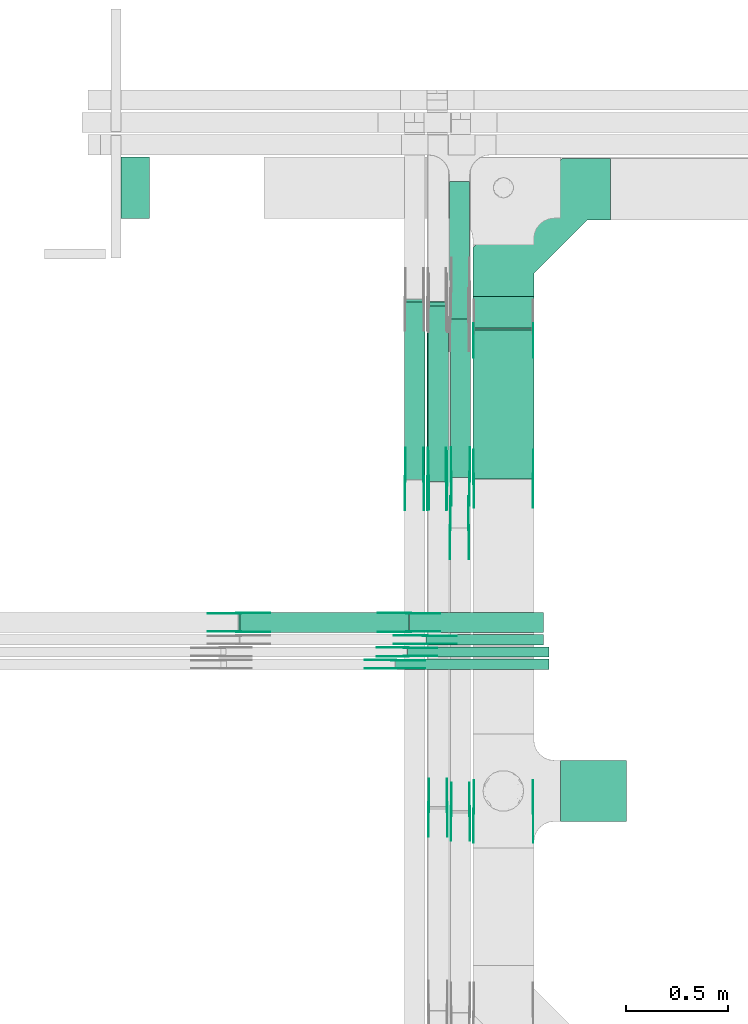
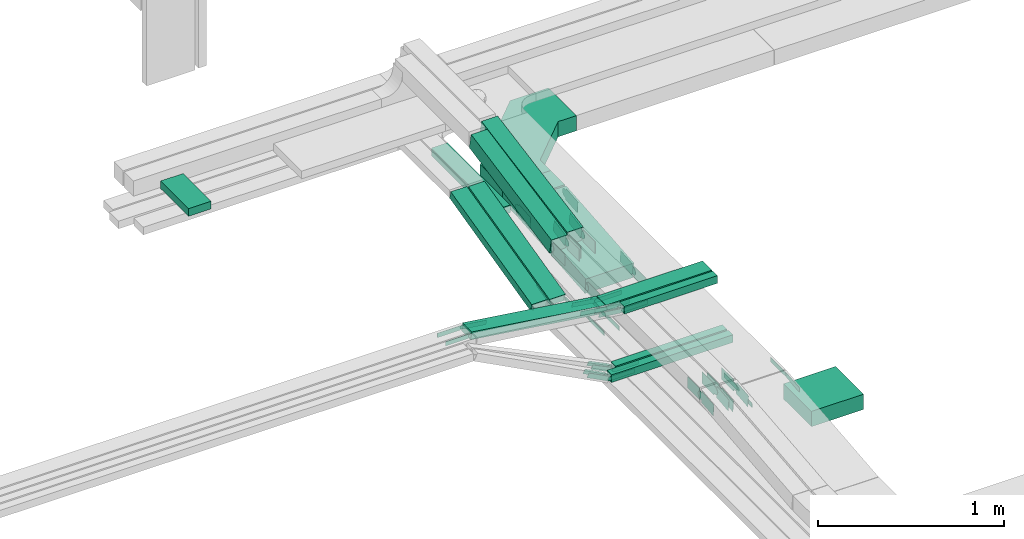
# One storey, part 8 of 33: 59 flow fittings, 14 flow segments.
"""IFC2X3 building model written with IfcOpenShell, lengths in millimetres."""

from ifc_helpers import new_model, entity, si_unit, converted_unit, derived_unit, direction, frame, frame_2d, origin, origin_2d_with_axis, place, context, subcontext, project, spatial, polyline, circle_curve, parameter, trimmed, segment, composite_curve, rectangle, outline, extrude, source, transform, mapped, material, type_object, type_shapes, element, save


model = new_model("IFC2X3")

# Units and contexts
model_context = context("Model", 3, precision=0.01, world=origin(), true_north=direction((6.12303176911189e-17, 1.0)))
body_context = subcontext(model_context, "Body", "Model", "MODEL_VIEW")
ifc_project = project(units=[si_unit("LENGTHUNIT", "METRE", prefix="MILLI"), si_unit("AREAUNIT", "SQUARE_METRE"), si_unit("VOLUMEUNIT", "CUBIC_METRE"), converted_unit("PLANEANGLEUNIT", "DEGREE", entity("IfcRatioMeasure", 0.0174532925199433), si_unit("PLANEANGLEUNIT", "RADIAN"), dimensions=[0, 0, 0, 0, 0, 0, 0]), si_unit("MASSUNIT", "GRAM", prefix="KILO"), derived_unit("MASSDENSITYUNIT", [(si_unit("MASSUNIT", "GRAM", prefix="KILO"), 1), (si_unit("LENGTHUNIT", "METRE"), -3)]), derived_unit("MOMENTOFINERTIAUNIT", [(si_unit("LENGTHUNIT", "METRE"), 4)]), si_unit("TIMEUNIT", "SECOND"), si_unit("FREQUENCYUNIT", "HERTZ"), si_unit("THERMODYNAMICTEMPERATUREUNIT", "DEGREE_CELSIUS"), derived_unit("THERMALTRANSMITTANCEUNIT", [(si_unit("MASSUNIT", "GRAM", prefix="KILO"), 1), (si_unit("THERMODYNAMICTEMPERATUREUNIT", "KELVIN"), -1), (si_unit("TIMEUNIT", "SECOND"), -3)]), derived_unit("VOLUMETRICFLOWRATEUNIT", [(si_unit("LENGTHUNIT", "METRE"), 3), (si_unit("TIMEUNIT", "SECOND"), -1)]), derived_unit("MASSFLOWRATEUNIT", [(si_unit("MASSUNIT", "GRAM", prefix="KILO"), 1), (si_unit("TIMEUNIT", "SECOND"), -1)]), derived_unit("ROTATIONALFREQUENCYUNIT", [(si_unit("TIMEUNIT", "SECOND"), -1)]), si_unit("ELECTRICCURRENTUNIT", "AMPERE"), si_unit("ELECTRICVOLTAGEUNIT", "VOLT"), si_unit("POWERUNIT", "WATT"), si_unit("FORCEUNIT", "NEWTON", prefix="KILO"), si_unit("ILLUMINANCEUNIT", "LUX"), si_unit("LUMINOUSFLUXUNIT", "LUMEN"), si_unit("LUMINOUSINTENSITYUNIT", "CANDELA"), derived_unit("USERDEFINED", [(si_unit("MASSUNIT", "GRAM", prefix="KILO"), -1), (si_unit("LENGTHUNIT", "METRE"), -2), (si_unit("TIMEUNIT", "SECOND"), 3), (si_unit("LUMINOUSFLUXUNIT", "LUMEN"), 1)]), derived_unit("LINEARVELOCITYUNIT", [(si_unit("LENGTHUNIT", "METRE"), 1), (si_unit("TIMEUNIT", "SECOND"), -1)]), si_unit("PRESSUREUNIT", "PASCAL"), derived_unit("USERDEFINED", [(si_unit("LENGTHUNIT", "METRE"), -2), (si_unit("MASSUNIT", "GRAM", prefix="KILO"), 1), (si_unit("TIMEUNIT", "SECOND"), -2)]), derived_unit("LINEARFORCEUNIT", [(si_unit("MASSUNIT", "GRAM", prefix="KILO"), 1), (si_unit("LENGTHUNIT", "METRE"), 1), (si_unit("TIMEUNIT", "SECOND"), -2), (si_unit("LENGTHUNIT", "METRE"), -1)]), derived_unit("PLANARFORCEUNIT", [(si_unit("MASSUNIT", "GRAM", prefix="KILO"), 1), (si_unit("LENGTHUNIT", "METRE"), 1), (si_unit("TIMEUNIT", "SECOND"), -2), (si_unit("LENGTHUNIT", "METRE"), -2)])], contexts=[model_context])

# Site, building, storey
site_placement = place(None, frame((0.0, -0.00077364408347762, 0.0)))
site = spatial("IfcSite", under=ifc_project, at=site_placement, CompositionType="ELEMENT")
building_placement = place(site_placement, origin())
building = spatial("IfcBuilding", under=site, at=building_placement, CompositionType="ELEMENT")
storey_placement = place(building_placement, frame((0.0, 0.0, 8100.0)))
storey = spatial("IfcBuildingStorey", under=building, at=storey_placement, CompositionType="ELEMENT", Elevation=8100.0)

# Flow segments
cable_carrier_segment_type = type_object("IfcCableCarrierSegmentType", PredefinedType="CABLETRAYSEGMENT")
flow_segment_1_placement = place(storey_placement, frame((18676.0523642072, 11226.2465616803, 2500.0)))
element("IfcFlowSegment", 1, at=flow_segment_1_placement, inside=storey, type_object=cable_carrier_segment_type, context=body_context, shape_type="SweptSolid", body=[
    extrude(rectangle(XDim=322.50000000005, YDim=300.000000000001, at=frame_2d((1.09423581307055e-12, -1.08002495835535e-12), x_axis=(1.0, 0.0))), frame((161.250000000024, 150.0, 0.0)), (0.0, 0.0, 1.0), 99.9999999999989),
])
flow_segment_2_placement = place(storey_placement, frame((18246.0523642072, 13645.8761095776, 2565.0)))
element("IfcFlowSegment", 2, at=flow_segment_2_placement, inside=storey, type_object=cable_carrier_segment_type, context=body_context, shape_type="SweptSolid", body=[
    extrude(rectangle(XDim=152.623116778442, YDim=300.000000000001, at=origin_2d_with_axis()), frame((150.0, 76.3115583892504, 0.0), z_axis=(0.0, 0.0, 1.0), x_axis=(0.0, 1.0, 0.0)), (0.0, 0.0, 1.0), 100.000000000001),
])
flow_segment_3_placement = place(storey_placement, frame((18246.0523642072, 12903.9587974972, 2500.48936950024)))
element("IfcFlowSegment", 3, at=flow_segment_3_placement, inside=storey, type_object=cable_carrier_segment_type, context=body_context, shape_type="SweptSolid", body=[
    extrude(rectangle(XDim=99.9999999999982, YDim=733.623391012319, at=frame_2d((1.05160324892495e-12, -9.59232693276135e-14), x_axis=(0.0, 1.0))), frame((0.0, 369.784999621505, 82.0106304997698), z_axis=(1.0, 0.0, 0.0), x_axis=(0.0, -0.996138692653759, -0.0877935361974901)), (0.0, 0.0, 1.0), 300.000000000001),
])
flow_segment_4_placement = place(storey_placement, frame((18131.0123642174, 13688.0907678717, 2565.34290576127)))
element("IfcFlowSegment", 4, at=flow_segment_4_placement, inside=storey, type_object=cable_carrier_segment_type, context=body_context, shape_type="SweptSolid", body=[
    extrude(rectangle(XDim=674.18746787465, YDim=99.9999999999989, at=frame_2d((-1.08002495835535e-12, -1.08357767203415e-12), x_axis=(1.0, 0.0))), frame((50.0, 337.093733937324, 0.0), z_axis=(0.0, 0.0, 1.0), x_axis=(0.0, -1.0, 0.0)), (0.0, 0.0, 1.0), 50.0000000000016),
])
flow_segment_5_placement = place(storey_placement, frame((17911.0123642174, 12903.423065774, 2501.78649472544)))
element("IfcFlowSegment", 5, at=flow_segment_5_placement, inside=storey, type_object=cable_carrier_segment_type, context=body_context, shape_type="SweptSolid", body=[
    extrude(rectangle(XDim=50.0000000000038, YDim=895.216651992344, at=frame_2d((7.95807864051312e-13, -1.30206956328038e-12), x_axis=(0.0, 1.0))), frame((0.0, 440.715328832416, 130.713505274547), z_axis=(1.0, 0.0, 0.0), x_axis=(0.0, 0.971320023080272, 0.237775971795595)), (0.0, 0.0, 1.0), 99.9999999999968),
])
flow_segment_6_placement = place(storey_placement, frame((18021.0123642174, 12903.423065774, 2497.25382466919)))
element("IfcFlowSegment", 6, at=flow_segment_6_placement, inside=storey, type_object=cable_carrier_segment_type, context=body_context, shape_type="SweptSolid", body=[
    extrude(rectangle(XDim=49.9999999999981, YDim=896.294412020018, at=frame_2d((-1.33582034322899e-12, -7.95807864051312e-13), x_axis=(0.0, 1.0))), frame((0.0, 441.238753779902, 130.841637993481), z_axis=(1.0, 0.0, 0.0), x_axis=(0.0, 0.971320023080293, 0.237775971795511)), (0.0, 0.0, 1.0), 99.9999999999989),
])
flow_segment_7_placement = place(storey_placement, frame((16522.305766128, 14182.2782357464, 2840.01712441882)))
element("IfcFlowSegment", 7, at=flow_segment_7_placement, inside=storey, type_object=cable_carrier_segment_type, context=body_context, shape_type="SweptSolid", body=[
    extrude(rectangle(XDim=140.194233872036, YDim=300.000000000001, at=frame_2d((1.08002495835535e-12, 0.0), x_axis=(1.0, 0.0))), frame((70.0971169360193, 150.0, 0.0), z_axis=(0.0, 0.0, 1.0), x_axis=(-1.0, 0.0, 0.0)), (0.0, 0.0, 1.0), 50.0000000000016),
])
flow_segment_8_placement = place(storey_placement, frame((18026.0523642073, 12892.2621557856, 2842.15623611343)))
element("IfcFlowSegment", 8, at=flow_segment_8_placement, inside=storey, type_object=cable_carrier_segment_type, context=body_context, shape_type="SweptSolid", body=[
    extrude(rectangle(XDim=100.000000000003, YDim=99.9999999999989, at=origin_2d_with_axis()), frame((50.0, 9.6684077088445, 49.0563134813011), z_axis=(0.0, 0.981126269625997, 0.193368154176885), x_axis=(0.0, -0.193368154176885, 0.981126269625997)), (0.0, 0.0, 1.0), 877.56328106953),
])
flow_segment_9_placement = place(storey_placement, frame((18136.0523642072, 12912.5437412531, 2841.91082895298)))
element("IfcFlowSegment", 9, at=flow_segment_9_placement, inside=storey, type_object=cable_carrier_segment_type, context=body_context, shape_type="SweptSolid", body=[
    extrude(rectangle(XDim=100.000000000003, YDim=99.9999999999989, at=frame_2d((0.0, 0.0), x_axis=(0.0, 1.0))), frame((50.0, 9.07991875445974, 49.1686391454205), z_axis=(0.0, 0.983372782908385, 0.181598375089147), x_axis=(-1.0, 0.0, 0.0)), (0.0, 0.0, 1.0), 935.905702587184),
])
flow_segment_10_placement = place(storey_placement, frame((18016.0659654674, 12091.7526237039, 2943.74568114772)))
element("IfcFlowSegment", 10, at=flow_segment_10_placement, inside=storey, type_object=cable_carrier_segment_type, context=body_context, shape_type="SweptSolid", body=[
    extrude(rectangle(XDim=577.162395130562, YDim=50.0000000000016, at=frame_2d((-1.08002495835535e-12, 1.08357767203415e-12), x_axis=(1.0, 0.0))), frame((288.581197565282, 25.0, 0.0), z_axis=(0.0, 0.0, 1.0), x_axis=(-1.0, 0.0, 0.0)), (0.0, 0.0, 1.0), 50.0000000000016),
])
flow_segment_11_placement = place(storey_placement, frame((17936.2406698045, 12151.7526237039, 2943.74698260951)))
element("IfcFlowSegment", 11, at=flow_segment_11_placement, inside=storey, type_object=cable_carrier_segment_type, context=body_context, shape_type="SweptSolid", body=[
    extrude(rectangle(XDim=656.987690793579, YDim=99.9999999999989, at=frame_2d((-2.18847162614111e-12, -1.08357767203415e-12), x_axis=(1.0, 0.0))), frame((328.493845396792, 50.0, 0.0), z_axis=(0.0, 0.0, 1.0), x_axis=(-1.0, 0.0, 0.0)), (0.0, 0.0, 1.0), 49.9999999999995),
])
flow_segment_12_placement = place(storey_placement, frame((17927.2924008445, 12031.7526237039, 2620.0)))
element("IfcFlowSegment", 12, at=flow_segment_12_placement, inside=storey, type_object=cable_carrier_segment_type, context=body_context, shape_type="SweptSolid", body=[
    extrude(rectangle(XDim=692.290561126432, YDim=50.0000000000016, at=frame_2d((0.0, 1.08357767203415e-12), x_axis=(1.0, 0.0))), frame((346.145280563216, 25.0, 0.0), z_axis=(0.0, 0.0, 1.0), x_axis=(-1.0, 0.0, 0.0)), (0.0, 0.0, 1.0), 50.0000000000016),
])
flow_segment_13_placement = place(storey_placement, frame((17867.7183834513, 11971.7526237039, 2620.0)))
element("IfcFlowSegment", 13, at=flow_segment_13_placement, inside=storey, type_object=cable_carrier_segment_type, context=body_context, shape_type="SweptSolid", body=[
    extrude(rectangle(XDim=751.864578519647, YDim=50.0000000000016, at=frame_2d((-1.08002495835535e-12, 0.0), x_axis=(1.0, 0.0))), frame((375.932289259825, 25.0, 0.0), z_axis=(0.0, 0.0, 1.0), x_axis=(-1.0, 0.0, 0.0)), (0.0, 0.0, 1.0), 50.0000000000016),
])
flow_segment_14_placement = place(storey_placement, frame((17099.1135286794, 12151.7526237039, 2944.40262224737)))
element("IfcFlowSegment", 14, at=flow_segment_14_placement, inside=storey, type_object=cable_carrier_segment_type, context=body_context, shape_type="SweptSolid", body=[
    extrude(rectangle(XDim=49.9999999999989, YDim=99.9999999999989, at=origin_2d_with_axis()), frame((3.45287315697074, 50.0, 140.181332888668), z_axis=(0.990416209044974, 0.0, -0.138114926278746), x_axis=(0.138114926278746, 0.0, 0.990416209044974)), (0.0, 0.0, 1.0), 835.687573909055),
])

# Flow fittings
ifc_material_1 = material()
cable_carrier_fitting_type_1 = type_object("IfcCableCarrierFittingType", Name="470_DKC_G5_Sheet horizontal bend:-", PredefinedType="NOTDEFINED", material=ifc_material_1)
shared_shape_1 = source(origin(), body_context, "Body", "SweptSolid", [
    extrude(outline(polyline([(-307.0, -369.0), (-68.8679656440352, -369.0), (369.0, 68.8679656440351), (369.0, 307.0), (69.0, 307.0), (69.0, 193.132034355964), (-193.132034355963, -69.0), (-307.0, -69.0), (-307.0, -369.0)])), frame((-219.0, 219.0, -50.0)), (0.0, 0.0, 1.0), 100.0),
])
type_shapes(cable_carrier_fitting_type_1, [shared_shape_1])
flow_fitting_placement = place(storey_placement, frame((18396.0523642072, 14324.4992263561, 2615.0), z_axis=(0.0, 0.0, 1.0), x_axis=(-1.0, 0.0, 0.0)))
element("IfcFlowFitting", 15, at=flow_fitting_placement, inside=storey, type_object=cable_carrier_fitting_type_1, material=ifc_material_1, Name="470_DKC_G5_Sheet horizontal bend:-", ObjectType="470_DKC_G5_Sheet horizontal bend:-", context=body_context, shape_type="MappedRepresentation", body=[
    mapped(shared_shape_1, transform((0.0, 0.0, 0.0), scale=1.0)),
])
ifc_material_2 = material(Name="G")
cable_carrier_fitting_type_2 = type_object("IfcCableCarrierFittingType", PredefinedType="NOTDEFINED", material=ifc_material_2)
shared_shape_2 = source(origin(), body_context, "Body", "SweptSolid", [
    extrude(outline(composite_curve([segment(trimmed(circle_curve(frame_2d((-44.5901162790698, 0.0), x_axis=(1.0, 0.0)), 12.5), [parameter(90.0000000000007)], [parameter(270.0)], True, "PARAMETER"), True, "CONTINUOUS"), segment(polyline([(-44.5901162790697, -12.5), (-33.0901162790698, -12.5)]), True, "CONTINUOUS"), segment(polyline([(-33.0901162790698, -12.5), (-31.2296511627907, -14.5)]), True, "CONTINUOUS"), segment(polyline([(-31.2296511627907, -14.5), (108.90988372093, -14.5)]), True, "CONTINUOUS"), segment(polyline([(108.90988372093, -14.5), (108.90988372093, 14.5)]), True, "CONTINUOUS"), segment(polyline([(108.90988372093, 14.5), (-31.2296511627907, 14.5)]), True, "CONTINUOUS"), segment(polyline([(-31.2296511627907, 14.5), (-33.0901162790698, 12.5)]), True, "CONTINUOUS"), segment(polyline([(-33.0901162790698, 12.5), (-44.5901162790699, 12.5)]), True, "CONTINUOUS")], self_intersect=False)), frame((44.5901162790698, 0.0, 0.0), z_axis=(0.0, 0.0, -1.0), x_axis=(1.0, 0.0, 0.0)), (0.0, 0.0, -1.0), 2.0),
])
type_shapes(cable_carrier_fitting_type_2, [shared_shape_2])
for number, where, z_axis, x_axis in (
    (16, (18541.5123642176, 11275.7784161575, 2865.01533161617), (1.0, 0.0, 0.0), (0.0, -0.994974854702737, -0.10012511427842)),
    (17, (17915.5523642073, 12904.9985534668, 2525.0), (-1.0, 0.0, 0.0), (0.0, -1.0, 0.0)),
    (18, (18025.5523642072, 12904.9985534668, 2520.46732994372), (-1.0, 0.0, 0.0), (0.0, -1.0, 0.0)),
    (19, (18135.5523642072, 12664.9985534667, 2520.32100561212), (-1.0, 0.0, 0.0), (0.0, -1.0, 0.0)),
    (20, (18013.2283605979, 12137.2126237141, 2968.7456811477), (0.0, 1.0, 0.0), (-0.992001694765699, 0.0, 0.126224552215409)),
    (21, (17933.2283605981, 12247.212623714, 2968.7469826095), (0.0, 1.0, 0.0), (-0.990416209044951, 0.0, 0.138114926278904)),
    (22, (17099.5829619717, 12247.212623714, 3085.0), (0.0, 1.0, 0.0), (0.990416209044951, 0.0, -0.138114926278904)),
    (23, (17859.5829619708, 12017.2126237141, 2645.0), (0.0, 1.0, 0.0), (-0.885831535280083, 0.0, 0.464006994670695)),
    (24, (17919.5829619709, 12077.2126237141, 2645.0), (0.0, 1.0, 0.0), (-0.898384360919165, 0.0, 0.439210132005016)),
):
    element("IfcFlowFitting", number, at=place(storey_placement, frame(where, z_axis=z_axis, x_axis=x_axis)), inside=storey, type_object=cable_carrier_fitting_type_2, material=ifc_material_2, context=body_context, shape_type="MappedRepresentation", body=[
        mapped(shared_shape_2, transform((0.0, 0.0, 0.0), scale=1.0)),
    ])
cable_carrier_fitting_type_3 = type_object("IfcCableCarrierFittingType", PredefinedType="NOTDEFINED", material=ifc_material_2)
shared_shape_3 = source(origin(), body_context, "Body", "SweptSolid", [
    extrude(outline(composite_curve([segment(trimmed(circle_curve(frame_2d((-44.5901162790697, 0.0), x_axis=(1.0, 0.0)), 12.5), [parameter(90.0000000000007)], [parameter(270.0)], True, "PARAMETER"), True, "CONTINUOUS"), segment(polyline([(-44.5901162790697, -12.5), (-33.0901162790697, -12.5)]), True, "CONTINUOUS"), segment(polyline([(-33.0901162790697, -12.5), (-31.2296511627907, -14.5)]), True, "CONTINUOUS"), segment(polyline([(-31.2296511627907, -14.5), (108.90988372093, -14.5)]), True, "CONTINUOUS"), segment(polyline([(108.90988372093, -14.5), (108.90988372093, 14.5)]), True, "CONTINUOUS"), segment(polyline([(108.90988372093, 14.5), (-31.2296511627907, 14.5)]), True, "CONTINUOUS"), segment(polyline([(-31.2296511627907, 14.5), (-33.0901162790698, 12.5)]), True, "CONTINUOUS"), segment(polyline([(-33.0901162790698, 12.5), (-44.5901162790699, 12.5)]), True, "CONTINUOUS")], self_intersect=False)), frame((44.5901162790697, 0.0, 0.0)), (0.0, 0.0, 1.0), 2.0),
])
type_shapes(cable_carrier_fitting_type_3, [shared_shape_3])
for number, where, z_axis, x_axis in (
    (25, (18250.5923641973, 11275.7784161575, 2865.01533161616), (-1.0, 0.0, 0.0), (0.0, -0.994974854702737, -0.10012511427842)),
    (26, (18006.4723642276, 12904.9985534668, 2525.0), (1.0, 0.0, 0.0), (0.0, -1.0, 0.0)),
    (27, (18116.4723642275, 12904.9985534668, 2520.46732994372), (1.0, 0.0, 0.0), (0.0, -1.0, 0.0)),
    (28, (18226.4723642276, 12664.9985534667, 2520.32100561212), (1.0, 0.0, 0.0), (0.0, -1.0, 0.0)),
    (29, (18013.2283605979, 12096.2926236938, 2968.7456811477), (0.0, -1.0, 0.0), (-0.992001694765699, 0.0, 0.126224552215409)),
    (30, (17933.2283605981, 12156.2926236937, 2968.74698260949), (0.0, -1.0, 0.0), (-0.990416209044951, 0.0, 0.138114926278904)),
    (31, (17099.5829619717, 12156.2926236937, 3085.0), (0.0, -1.0, 0.0), (0.990416209044951, 0.0, -0.138114926278904)),
    (32, (17859.5829619708, 11976.2926236938, 2645.0), (0.0, -1.0, 0.0), (-0.885831535280083, 0.0, 0.464006994670695)),
    (33, (17919.5829619709, 12036.2926236938, 2645.0), (0.0, -1.0, 0.0), (-0.898384360919165, 0.0, 0.439210132005016)),
):
    element("IfcFlowFitting", number, at=place(storey_placement, frame(where, z_axis=z_axis, x_axis=x_axis)), inside=storey, type_object=cable_carrier_fitting_type_3, material=ifc_material_2, context=body_context, shape_type="MappedRepresentation", body=[
        mapped(shared_shape_3, transform((0.0, 0.0, 0.0), scale=1.0)),
    ])
cable_carrier_fitting_type_4 = type_object("IfcCableCarrierFittingType", PredefinedType="NOTDEFINED", material=ifc_material_2)
shared_shape_4 = source(origin(), body_context, "Body", "SweptSolid", [
    extrude(outline(composite_curve([segment(trimmed(circle_curve(frame_2d((-44.5901162790698, 0.0), x_axis=(1.0, 0.0)), 12.5), [parameter(90.0000000000007)], [parameter(270.0)], True, "PARAMETER"), True, "CONTINUOUS"), segment(polyline([(-44.5901162790697, -12.5), (-33.0901162790698, -12.5)]), True, "CONTINUOUS"), segment(polyline([(-33.0901162790698, -12.5), (-31.2296511627907, -14.5)]), True, "CONTINUOUS"), segment(polyline([(-31.2296511627907, -14.5), (108.90988372093, -14.5)]), True, "CONTINUOUS"), segment(polyline([(108.90988372093, -14.5), (108.90988372093, 14.5)]), True, "CONTINUOUS"), segment(polyline([(108.90988372093, 14.5), (-31.2296511627907, 14.5)]), True, "CONTINUOUS"), segment(polyline([(-31.2296511627907, 14.5), (-33.0901162790698, 12.5)]), True, "CONTINUOUS"), segment(polyline([(-33.0901162790698, 12.5), (-44.5901162790699, 12.5)]), True, "CONTINUOUS")], self_intersect=False)), frame((44.5901162790698, 0.0, 0.0), z_axis=(0.0, 0.0, -1.0), x_axis=(1.0, 0.0, 0.0)), (0.0, 0.0, -1.0), 2.0),
])
type_shapes(cable_carrier_fitting_type_4, [shared_shape_4])
for number, where, z_axis, x_axis in (
    (34, (18252.5923641973, 11275.7784161575, 2865.01533161616), (-1.0, 0.0, 0.0), (0.0, 1.0, 0.0)),
    (35, (18004.4723642276, 12904.9985534668, 2525.0), (1.0, 0.0, 0.0), (0.0, 0.971320023080276, 0.237775971795579)),
    (36, (18114.4723642275, 12904.9985534668, 2520.46732994372), (1.0, 0.0, 0.0), (0.0, 0.971320023080296, 0.237775971795496)),
    (37, (18224.4723642276, 12664.9985534666, 2520.32100561213), (1.0, 0.0, 0.0), (0.0, 0.997656992775832, 0.0684143608132392)),
    (38, (18013.2283605979, 12098.2926236938, 2968.74568114771), (0.0, -1.0, 0.0), (1.0, 0.0, 0.0)),
    (39, (17933.2283605981, 12158.2926236937, 2968.7469826095), (0.0, -1.0, 0.0), (1.0, 0.0, 0.0)),
    (40, (17099.5829619717, 12158.2926236937, 3085.0), (0.0, -1.0, 0.0), (-1.0, 0.0, 0.0)),
    (41, (17859.5829619708, 11978.2926236938, 2645.0), (0.0, -1.0, 0.0), (1.0, 0.0, 0.0)),
    (42, (17919.5829619709, 12038.2926236938, 2645.0), (0.0, -1.0, 0.0), (1.0, 0.0, 0.0)),
):
    element("IfcFlowFitting", number, at=place(storey_placement, frame(where, z_axis=z_axis, x_axis=x_axis)), inside=storey, type_object=cable_carrier_fitting_type_4, material=ifc_material_2, context=body_context, shape_type="MappedRepresentation", body=[
        mapped(shared_shape_4, transform((0.0, 0.0, 0.0), scale=1.0)),
    ])
cable_carrier_fitting_type_5 = type_object("IfcCableCarrierFittingType", PredefinedType="NOTDEFINED", material=ifc_material_2)
shared_shape_5 = source(origin(), body_context, "Body", "SweptSolid", [
    extrude(outline(composite_curve([segment(trimmed(circle_curve(frame_2d((-44.5901162790697, 0.0), x_axis=(1.0, 0.0)), 12.5), [parameter(90.0000000000007)], [parameter(270.0)], True, "PARAMETER"), True, "CONTINUOUS"), segment(polyline([(-44.5901162790697, -12.5), (-33.0901162790697, -12.5)]), True, "CONTINUOUS"), segment(polyline([(-33.0901162790697, -12.5), (-31.2296511627907, -14.5)]), True, "CONTINUOUS"), segment(polyline([(-31.2296511627907, -14.5), (108.90988372093, -14.5)]), True, "CONTINUOUS"), segment(polyline([(108.90988372093, -14.5), (108.90988372093, 14.5)]), True, "CONTINUOUS"), segment(polyline([(108.90988372093, 14.5), (-31.2296511627907, 14.5)]), True, "CONTINUOUS"), segment(polyline([(-31.2296511627907, 14.5), (-33.0901162790698, 12.5)]), True, "CONTINUOUS"), segment(polyline([(-33.0901162790698, 12.5), (-44.5901162790699, 12.5)]), True, "CONTINUOUS")], self_intersect=False)), frame((44.5901162790697, 0.0, 0.0)), (0.0, 0.0, 1.0), 2.0),
])
type_shapes(cable_carrier_fitting_type_5, [shared_shape_5])
for number, where, z_axis, x_axis in (
    (43, (18539.5123642176, 11275.7784161575, 2865.01533161616), (1.0, 0.0, 0.0), (0.0, 1.0, 0.0)),
    (44, (17917.5523642073, 12904.9985534668, 2525.0), (-1.0, 0.0, 0.0), (0.0, 0.971320023080276, 0.237775971795579)),
    (45, (18027.5523642072, 12904.9985534668, 2520.46732994373), (-1.0, 0.0, 0.0), (0.0, 0.971320023080296, 0.237775971795496)),
    (46, (18137.5523642072, 12664.9985534666, 2520.32100561213), (-1.0, 0.0, 0.0), (0.0, 0.997656992775832, 0.0684143608132392)),
    (47, (18013.2283605979, 12135.2126237141, 2968.74568114771), (0.0, 1.0, 0.0), (1.0, 0.0, 0.0)),
    (48, (17933.2283605981, 12245.212623714, 2968.7469826095), (0.0, 1.0, 0.0), (1.0, 0.0, 0.0)),
    (49, (17099.5829619717, 12245.212623714, 3085.0), (0.0, 1.0, 0.0), (-1.0, 0.0, 0.0)),
    (50, (17859.5829619708, 12015.2126237141, 2645.0), (0.0, 1.0, 0.0), (1.0, 0.0, 0.0)),
    (51, (17919.5829619709, 12075.2126237141, 2645.0), (0.0, 1.0, 0.0), (1.0, 0.0, 0.0)),
):
    element("IfcFlowFitting", number, at=place(storey_placement, frame(where, z_axis=z_axis, x_axis=x_axis)), inside=storey, type_object=cable_carrier_fitting_type_5, material=ifc_material_2, context=body_context, shape_type="MappedRepresentation", body=[
        mapped(shared_shape_5, transform((0.0, 0.0, 0.0), scale=1.0)),
    ])
cable_carrier_fitting_type_6 = type_object("IfcCableCarrierFittingType", PredefinedType="NOTDEFINED", material=ifc_material_2)
shared_shape_6 = source(origin(), body_context, "Body", "SweptSolid", [
    extrude(outline(composite_curve([segment(trimmed(circle_curve(frame_2d((-41.4651162790697, 0.0), x_axis=(1.0, 0.0)), 25.0), [parameter(90.0000000000007)], [parameter(270.0)], True, "PARAMETER"), True, "CONTINUOUS"), segment(polyline([(-41.4651162790697, -25.0), (-29.9651162790697, -25.0)]), True, "CONTINUOUS"), segment(polyline([(-29.9651162790697, -25.0), (-28.1046511627907, -38.5)]), True, "CONTINUOUS"), segment(polyline([(-28.1046511627907, -38.5), (99.5348837209303, -38.5)]), True, "CONTINUOUS"), segment(polyline([(99.5348837209303, -38.5), (99.5348837209303, 38.5)]), True, "CONTINUOUS"), segment(polyline([(99.5348837209303, 38.5), (-28.1046511627907, 38.5)]), True, "CONTINUOUS"), segment(polyline([(-28.1046511627907, 38.5), (-29.9651162790697, 25.0)]), True, "CONTINUOUS"), segment(polyline([(-29.9651162790697, 25.0), (-41.46511627907, 25.0)]), True, "CONTINUOUS")], self_intersect=False)), frame((41.4651162790697, 0.0, 0.0), z_axis=(0.0, 0.0, -1.0), x_axis=(1.0, 0.0, 0.0)), (0.0, 0.0, -1.0), 2.0),
])
type_shapes(cable_carrier_fitting_type_6, [shared_shape_6])
for number, where, z_axis, x_axis in (
    (52, (18541.5123642174, 13642.501098777, 2615.0), (1.0, 0.0, 0.0), (0.0, -0.996138692653759, -0.0877935361974902)),
    (53, (18541.5123642174, 12904.9864954604, 2550.0), (1.0, 0.0, 0.0), (0.0, 0.996138692653759, 0.0877935361974902)),
    (54, (18231.5123642174, 12915.7782357459, 2890.0), (1.0, 0.0, 0.0), (0.0, 0.983372782908371, 0.181598375089224)),
    (55, (18121.5123642176, 11295.7782357464, 2890.0), (1.0, 0.0, 0.0), (0.0, -0.994903033239732, -0.100836275468608)),
    (56, (18231.5123642175, 11275.7782357457, 2890.0), (1.0, 0.0, 0.0), (0.0, -0.994821450765371, -0.101637990422292)),
    (57, (18121.5123642175, 12895.7782357478, 2890.0), (1.0, 0.0, 0.0), (0.0, 0.981126269625946, 0.193368154177143)),
):
    element("IfcFlowFitting", number, at=place(storey_placement, frame(where, z_axis=z_axis, x_axis=x_axis)), inside=storey, type_object=cable_carrier_fitting_type_6, material=ifc_material_2, context=body_context, shape_type="MappedRepresentation", body=[
        mapped(shared_shape_6, transform((0.0, 0.0, 0.0), scale=1.0)),
    ])
cable_carrier_fitting_type_7 = type_object("IfcCableCarrierFittingType", PredefinedType="NOTDEFINED", material=ifc_material_2)
shared_shape_7 = source(origin(), body_context, "Body", "SweptSolid", [
    extrude(outline(composite_curve([segment(trimmed(circle_curve(frame_2d((-41.4651162790697, 0.0), x_axis=(1.0, 0.0)), 25.0), [parameter(90.0000000000007)], [parameter(270.0)], True, "PARAMETER"), True, "CONTINUOUS"), segment(polyline([(-41.4651162790697, -25.0), (-29.9651162790697, -25.0)]), True, "CONTINUOUS"), segment(polyline([(-29.9651162790697, -25.0), (-28.1046511627907, -38.5)]), True, "CONTINUOUS"), segment(polyline([(-28.1046511627907, -38.5), (99.5348837209303, -38.5)]), True, "CONTINUOUS"), segment(polyline([(99.5348837209303, -38.5), (99.5348837209303, 38.5)]), True, "CONTINUOUS"), segment(polyline([(99.5348837209303, 38.5), (-28.1046511627907, 38.5)]), True, "CONTINUOUS"), segment(polyline([(-28.1046511627907, 38.5), (-29.9651162790697, 25.0)]), True, "CONTINUOUS"), segment(polyline([(-29.9651162790697, 25.0), (-41.46511627907, 25.0)]), True, "CONTINUOUS")], self_intersect=False)), frame((41.4651162790697, 0.0, 0.0)), (0.0, 0.0, 1.0), 2.0),
])
type_shapes(cable_carrier_fitting_type_7, [shared_shape_7])
for number, where, z_axis, x_axis in (
    (58, (18250.5923641971, 13642.501098777, 2615.0), (-1.0, 0.0, 0.0), (0.0, -0.996138692653759, -0.0877935361974902)),
    (59, (18250.592364197, 12904.9864954604, 2550.0), (-1.0, 0.0, 0.0), (0.0, 0.996138692653759, 0.0877935361974902)),
    (60, (18140.5923641971, 12915.7782357459, 2890.0), (-1.0, 0.0, 0.0), (0.0, 0.983372782908371, 0.181598375089224)),
    (61, (18030.5923641973, 11295.7782357464, 2890.0), (-1.0, 0.0, 0.0), (0.0, -0.994903033239732, -0.100836275468608)),
    (62, (18140.5923641972, 11275.7782357457, 2890.0), (-1.0, 0.0, 0.0), (0.0, -0.994821450765371, -0.101637990422292)),
    (63, (18030.5923641972, 12895.7782357478, 2890.0), (-1.0, 0.0, 0.0), (0.0, 0.981126269625946, 0.193368154177143)),
):
    element("IfcFlowFitting", number, at=place(storey_placement, frame(where, z_axis=z_axis, x_axis=x_axis)), inside=storey, type_object=cable_carrier_fitting_type_7, material=ifc_material_2, context=body_context, shape_type="MappedRepresentation", body=[
        mapped(shared_shape_7, transform((0.0, 0.0, 0.0), scale=1.0)),
    ])
cable_carrier_fitting_type_8 = type_object("IfcCableCarrierFittingType", PredefinedType="NOTDEFINED", material=ifc_material_2)
shared_shape_8 = source(origin(), body_context, "Body", "SweptSolid", [
    extrude(outline(composite_curve([segment(trimmed(circle_curve(frame_2d((-41.4651162790697, 0.0), x_axis=(1.0, 0.0)), 25.0), [parameter(90.0000000000007)], [parameter(270.0)], True, "PARAMETER"), True, "CONTINUOUS"), segment(polyline([(-41.4651162790697, -25.0), (-29.9651162790697, -25.0)]), True, "CONTINUOUS"), segment(polyline([(-29.9651162790697, -25.0), (-28.1046511627907, -38.5)]), True, "CONTINUOUS"), segment(polyline([(-28.1046511627907, -38.5), (99.5348837209303, -38.5)]), True, "CONTINUOUS"), segment(polyline([(99.5348837209303, -38.5), (99.5348837209303, 38.5)]), True, "CONTINUOUS"), segment(polyline([(99.5348837209303, 38.5), (-28.1046511627907, 38.5)]), True, "CONTINUOUS"), segment(polyline([(-28.1046511627907, 38.5), (-29.9651162790697, 25.0)]), True, "CONTINUOUS"), segment(polyline([(-29.9651162790697, 25.0), (-41.46511627907, 25.0)]), True, "CONTINUOUS")], self_intersect=False)), frame((41.4651162790697, 0.0, 0.0), z_axis=(0.0, 0.0, -1.0), x_axis=(1.0, 0.0, 0.0)), (0.0, 0.0, -1.0), 2.0),
])
type_shapes(cable_carrier_fitting_type_8, [shared_shape_8])
for number, where, z_axis, x_axis in (
    (64, (18252.592364197, 12904.9864954604, 2550.0), (-1.0, 0.0, 0.0), (0.0, -1.0, 0.0)),
    (65, (18142.5923641971, 12915.7782357459, 2890.0), (-1.0, 0.0, 0.0), (0.0, -1.0, 0.0)),
    (66, (18032.5923641973, 11295.7782357463, 2890.0), (-1.0, 0.0, 0.0), (0.0, 1.0, 0.0)),
    (67, (18142.5923641972, 11275.7782357457, 2890.0), (-1.0, 0.0, 0.0), (0.0, 1.0, 0.0)),
    (68, (18032.5923641972, 12895.7782357478, 2890.0), (-1.0, 0.0, 0.0), (0.0, -1.0, 0.0)),
):
    element("IfcFlowFitting", number, at=place(storey_placement, frame(where, z_axis=z_axis, x_axis=x_axis)), inside=storey, type_object=cable_carrier_fitting_type_8, material=ifc_material_2, context=body_context, shape_type="MappedRepresentation", body=[
        mapped(shared_shape_8, transform((0.0, 0.0, 0.0), scale=1.0)),
    ])
cable_carrier_fitting_type_9 = type_object("IfcCableCarrierFittingType", PredefinedType="NOTDEFINED", material=ifc_material_2)
shared_shape_9 = source(origin(), body_context, "Body", "SweptSolid", [
    extrude(outline(composite_curve([segment(trimmed(circle_curve(frame_2d((-41.4651162790697, 0.0), x_axis=(1.0, 0.0)), 25.0), [parameter(90.0000000000007)], [parameter(270.0)], True, "PARAMETER"), True, "CONTINUOUS"), segment(polyline([(-41.4651162790697, -25.0), (-29.9651162790697, -25.0)]), True, "CONTINUOUS"), segment(polyline([(-29.9651162790697, -25.0), (-28.1046511627907, -38.5)]), True, "CONTINUOUS"), segment(polyline([(-28.1046511627907, -38.5), (99.5348837209303, -38.5)]), True, "CONTINUOUS"), segment(polyline([(99.5348837209303, -38.5), (99.5348837209303, 38.5)]), True, "CONTINUOUS"), segment(polyline([(99.5348837209303, 38.5), (-28.1046511627907, 38.5)]), True, "CONTINUOUS"), segment(polyline([(-28.1046511627907, 38.5), (-29.9651162790697, 25.0)]), True, "CONTINUOUS"), segment(polyline([(-29.9651162790697, 25.0), (-41.46511627907, 25.0)]), True, "CONTINUOUS")], self_intersect=False)), frame((41.4651162790697, 0.0, 0.0)), (0.0, 0.0, 1.0), 2.0),
])
type_shapes(cable_carrier_fitting_type_9, [shared_shape_9])
for number, where, z_axis, x_axis in (
    (69, (18539.5123642174, 12904.9864954604, 2550.0), (1.0, 0.0, 0.0), (0.0, -1.0, 0.0)),
    (70, (18229.5123642174, 12915.7782357459, 2890.0), (1.0, 0.0, 0.0), (0.0, -1.0, 0.0)),
    (71, (18119.5123642176, 11295.7782357463, 2890.0), (1.0, 0.0, 0.0), (0.0, 1.0, 0.0)),
    (72, (18229.5123642175, 11275.7782357457, 2890.0), (1.0, 0.0, 0.0), (0.0, 1.0, 0.0)),
    (73, (18119.5123642175, 12895.7782357478, 2890.0), (1.0, 0.0, 0.0), (0.0, -1.0, 0.0)),
):
    element("IfcFlowFitting", number, at=place(storey_placement, frame(where, z_axis=z_axis, x_axis=x_axis)), inside=storey, type_object=cable_carrier_fitting_type_9, material=ifc_material_2, context=body_context, shape_type="MappedRepresentation", body=[
        mapped(shared_shape_9, transform((0.0, 0.0, 0.0), scale=1.0)),
    ])

save(model, "model.ifc")
